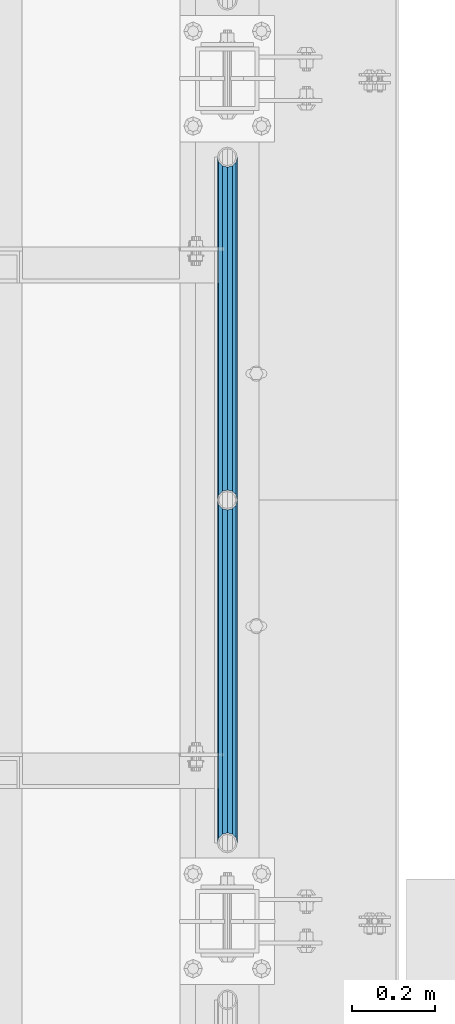
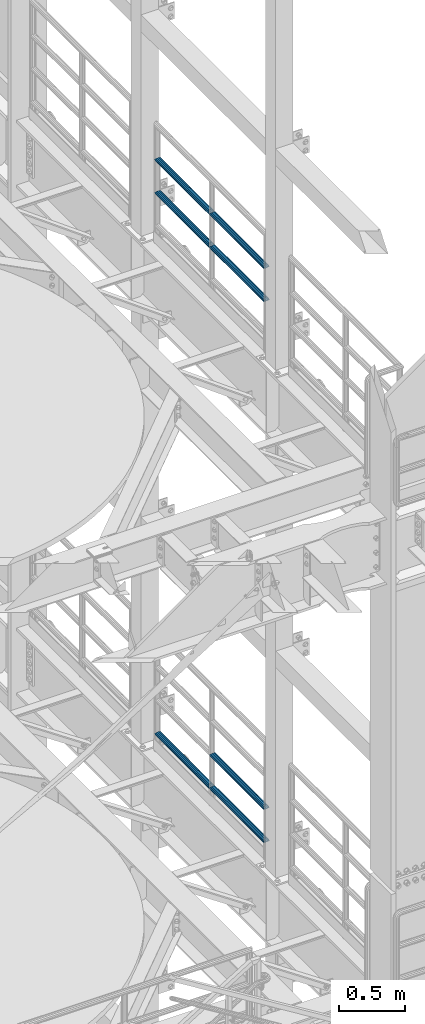
# One storey, part 1263 of 1876: 7 beams, 2 elements without a shape of their own.
"""IFC2X3 building model written with IfcOpenShell, lengths in millimetres."""

import ifcopenshell
import ifcopenshell.guid

model = None  # the IFC model being written
_history = None  # IfcOwnerHistory: only IFC2X3 demands one
_inside = {}  # id of a spatial element -> (the spatial element, [elements in it])
_under = {}  # id of a project, library or spatial element -> (it, [spatial elements below it])
_declared = {}  # id of a project -> (the project, [libraries it declares])
_typed = {}  # id of a type object -> (the type object, [elements of that type])
_made_of = {}  # id of a material, layer set ... -> (it, [elements and type objects made of it])


def new_model(schema):
    """Start an empty IFC model of exactly this schema.

    Asked for "IFC4X3", IfcOpenShell would pick the latest addendum, in which some entities
    have other attributes; the version numbers below select the first issue.
    IFC2X3 requires an IfcOwnerHistory on every rooted entity: one is made here for all.
    """
    global model, _history
    if schema == "IFC4X3":
        model = ifcopenshell.file(schema_version=(4, 3, 0, 0))
    else:
        model = ifcopenshell.file(schema=schema)
    _inside.clear()
    _under.clear()
    _declared.clear()
    _typed.clear()
    _made_of.clear()
    _history = None
    if model.schema == "IFC2X3":
        org = make("IfcOrganization", Name="unknown")
        user = make(
            "IfcPersonAndOrganization",
            ThePerson=make("IfcPerson", FamilyName="unknown"),
            TheOrganization=org,
        )
        app = make(
            "IfcApplication",
            ApplicationDeveloper=org,
            Version="unknown",
            ApplicationFullName="unknown",
            ApplicationIdentifier="unknown",
        )
        _history = make(
            "IfcOwnerHistory",
            OwningUser=user,
            OwningApplication=app,
            ChangeAction="ADDED",
            CreationDate=0,
        )
    return model


def make(cls, **values):
    """One entity of the class cls with the attributes given. An attribute that is None is left unset."""
    return model.create_entity(
        cls, **{name: value for name, value in values.items() if value is not None}
    )


def rooted(cls, **values):
    """An entity with a GlobalId (a new one), such as an element, a storey or a relation."""
    return make(cls, GlobalId=ifcopenshell.guid.new(), OwnerHistory=_history, **values)


def si_unit(unit_type, name, prefix=None):
    """IfcSIUnit, for example si_unit("LENGTHUNIT", "METRE", prefix="MILLI")."""
    return make("IfcSIUnit", UnitType=unit_type, Prefix=prefix, Name=name)


def assignment(units):
    """IfcUnitAssignment: the units of a project."""
    return None if units is None else make("IfcUnitAssignment", Units=units)


def point(xyz):
    """IfcCartesianPoint."""
    return None if xyz is None else make("IfcCartesianPoint", Coordinates=xyz)


def direction(xyz):
    """IfcDirection."""
    return None if xyz is None else make("IfcDirection", DirectionRatios=xyz)


def frame(location, z_axis=None, x_axis=None):
    """IfcAxis2Placement3D, a coordinate frame: its origin and axes. An axis left out is left unset."""
    return make(
        "IfcAxis2Placement3D",
        Location=point(location),
        Axis=direction(z_axis),
        RefDirection=direction(x_axis),
    )


def origin_with_axes():
    """The frame at (0, 0, 0) with the z axis (0, 0, 1) and the x axis (1, 0, 0) written out."""
    return frame((0.0, 0.0, 0.0), z_axis=(0.0, 0.0, 1.0), x_axis=(1.0, 0.0, 0.0))


def place(relative_to, where):
    """IfcLocalPlacement: puts the frame where relative to a parent placement (None: the world)."""
    return make(
        "IfcLocalPlacement", PlacementRelTo=relative_to, RelativePlacement=where
    )


def context(
    kind, dimensions, precision=None, world=None, true_north=None, identifier=None
):
    """IfcGeometricRepresentationContext, for example the 3D "Model" context."""
    return make(
        "IfcGeometricRepresentationContext",
        ContextIdentifier=identifier,
        ContextType=kind,
        CoordinateSpaceDimension=dimensions,
        Precision=precision,
        WorldCoordinateSystem=world,
        TrueNorth=true_north,
    )


def subcontext(parent, identifier, kind, view, scale=None):
    """IfcGeometricRepresentationSubContext, for example "Body" below "Model"."""
    return make(
        "IfcGeometricRepresentationSubContext",
        ContextIdentifier=identifier,
        ContextType=kind,
        ParentContext=parent,
        TargetScale=scale,
        TargetView=view,
    )


def project(units=None, contexts=None):
    """IfcProject with its units and contexts."""
    return rooted(
        "IfcProject",
        Name="project",
        RepresentationContexts=contexts,
        UnitsInContext=assignment(units),
    )


def spatial(cls, under=None, at=None, **own):
    """A site, building, storey or space (cls), placed at a placement, below another one or the project."""
    s = rooted(cls, ObjectPlacement=at, **own)
    if under is not None:
        _under.setdefault(under.id(), (under, []))[1].append(s)
    return s


def faces_of(points, faces, orient=None, outer=None):
    """IfcFace entities. A face is a list of loops; a loop is a list of indices into points, from 0.

    orient and outer hold one flag for each loop. By default every Orientation is true, the
    first loop of a face is its IfcFaceOuterBound and the others are IfcFaceBound.
    """
    made = []
    for i, loops in enumerate(faces):
        bounds = []
        for j, loop in enumerate(loops):
            is_outer = j == 0 if outer is None else outer[i][j]
            bounds.append(
                make(
                    "IfcFaceOuterBound" if is_outer else "IfcFaceBound",
                    Bound=make("IfcPolyLoop", Polygon=[points[k] for k in loop]),
                    Orientation=True if orient is None else orient[i][j],
                )
            )
        made.append(make("IfcFace", Bounds=bounds))
    return made


def faceted_brep(points, faces, orient=None, outer=None, voids=None):
    """IfcFacetedBrep: a solid bounded by flat faces; with voids (closed shells), ...WithVoids."""
    shared = [point(p) for p in points]
    hull = make("IfcClosedShell", CfsFaces=faces_of(shared, faces, orient, outer))
    if voids is None:
        return make("IfcFacetedBrep", Outer=hull)
    return make(
        "IfcFacetedBrepWithVoids",
        Outer=hull,
        Voids=[
            make(cls, CfsFaces=faces_of(shared, fs, o, b)) for cls, fs, o, b in voids
        ],
    )


def shape(context_of_items, identifier, shape_type, items):
    """IfcShapeRepresentation: the items that make up one representation, for example the "Body"."""
    return make(
        "IfcShapeRepresentation",
        ContextOfItems=context_of_items,
        RepresentationIdentifier=identifier,
        RepresentationType=shape_type,
        Items=items,
    )


def material(Name=None, Category=None):
    """IfcMaterial."""
    return make("IfcMaterial", Name=Name, Category=Category)


def made_of(thing, what):
    """Note that an element or type object is made of a material, layer set ...; save() writes the relation."""
    if what is not None:
        _made_of.setdefault(what.id(), (what, []))[1].append(thing)
    return thing


def type_object(cls, material=None, **own):
    """A type object (cls), such as IfcWallType, which elements share."""
    return made_of(rooted(cls, **own), material)


def element(
    cls,
    number,
    at=None,
    inside=None,
    cuts=None,
    type_object=None,
    material=None,
    context=None,
    identifier="Body",
    shape_type=None,
    held_by="IfcProductDefinitionShape",
    body=None,
    shapes=None,
    **own,
):
    """One element of the class cls, such as IfcWall. Its Tag is "e" and its number.

    at: its placement. inside: the storey or other place that contains it. cuts: it is an
    opening in that element (IfcRelVoidsElement). A single representation is given by context,
    identifier, shape_type and body (its items); several are given by shapes. held_by: the class
    of the entity that holds the representations. save() writes the other relations.
    """
    e = rooted(cls, Tag="e%d" % number, ObjectPlacement=at, **own)
    if body is not None:
        shapes = [shape(context, identifier, shape_type, body)]
    if shapes is not None:
        e.Representation = make(held_by, Representations=shapes)
    if inside is not None:
        _inside.setdefault(inside.id(), (inside, []))[1].append(e)
    if cuts is not None:
        rooted(
            "IfcRelVoidsElement", RelatingBuildingElement=cuts, RelatedOpeningElement=e
        )
    if type_object is not None:
        _typed.setdefault(type_object.id(), (type_object, []))[1].append(e)
    return made_of(e, material)


def aggregate(whole, parts):
    """IfcRelAggregates: a whole, such as a stair, and the parts it consists of."""
    return rooted("IfcRelAggregates", RelatingObject=whole, RelatedObjects=parts)


def save(model, path):
    """Write the relations noted so far, then the file.

    IfcRelAggregates (storeys below a building ...), IfcRelContainedInSpatialStructure (elements
    in a storey), IfcRelDefinesByType, IfcRelAssociatesMaterial and IfcRelDeclares: one each for
    every whole, place, type object, material and project.
    """
    for whole, parts in _under.values():
        aggregate(whole, parts)
    for where, things in _inside.values():
        rooted(
            "IfcRelContainedInSpatialStructure",
            RelatedElements=things,
            RelatingStructure=where,
        )
    for kind, things in _typed.values():
        rooted("IfcRelDefinesByType", RelatedObjects=things, RelatingType=kind)
    for what, things in _made_of.values():
        rooted("IfcRelAssociatesMaterial", RelatedObjects=things, RelatingMaterial=what)
    for by, libraries in _declared.values():
        rooted("IfcRelDeclares", RelatingContext=by, RelatedDefinitions=libraries)
    model.write(path)


model = new_model("IFC2X3")

# Units and contexts
model_context = context("Model", 3, precision=1e-05, world=origin_with_axes())
body_context = subcontext(model_context, "Body", "Model", "MODEL_VIEW")
ifc_project = project(units=[si_unit("LENGTHUNIT", "METRE", prefix="MILLI"), si_unit("AREAUNIT", "SQUARE_METRE"), si_unit("VOLUMEUNIT", "CUBIC_METRE"), si_unit("MASSUNIT", "GRAM", prefix="KILO"), si_unit("TIMEUNIT", "SECOND"), si_unit("PLANEANGLEUNIT", "RADIAN"), si_unit("SOLIDANGLEUNIT", "STERADIAN"), si_unit("THERMODYNAMICTEMPERATUREUNIT", "DEGREE_CELSIUS"), si_unit("LUMINOUSINTENSITYUNIT", "LUMEN")], contexts=[model_context])

# Site, building, storey
site_placement = place(None, origin_with_axes())
site = spatial("IfcSite", under=ifc_project, at=site_placement, CompositionType="ELEMENT")
building_placement = place(site_placement, origin_with_axes())
building = spatial("IfcBuilding", under=site, at=building_placement, Name="Undefined", CompositionType="ELEMENT")
storey_placement = place(building_placement, origin_with_axes())
storey = spatial("IfcBuildingStorey", under=building, at=storey_placement, Name="Undefined", CompositionType="ELEMENT", Elevation=0.0)

# Assembly, beams
assembly_1_placement = place(storey_placement, origin_with_axes())
assembly_1 = element("IfcElementAssembly", 1, at=assembly_1_placement, inside=storey, Name="RAIL", AssemblyPlace="NOTDEFINED", PredefinedType="RIGID_FRAME")
ifc_material = material()
beam_type = type_object("IfcBeamType", Name="PIPE1-1/2SCH40", PredefinedType="NOTDEFINED")
beam_1_placement = place(assembly_1_placement, frame((7620.0, -2350.77, 18449.925), z_axis=(0.0, 0.0, -1.0), x_axis=(0.0, 1.0, 0.0)))
beam_1 = element("IfcBeam", 2, at=beam_1_placement, type_object=beam_type, material=ifc_material, Name="RAIL", ObjectType="PIPE1-1/2SCH40", context=body_context, shape_type="Brep", body=[
    faceted_brep([(0.0, 24.1299999999992, 0.0), (12.0650000000064, 20.8971929933177, -12.0649999999987), (12.0650000000064, 20.8971929933177, 12.0649999999987), (12.0650000000064, -20.8971929933177, 12.0649999999987), (12.0650000000064, -20.8971929933177, -12.0649999999987), (0.0, -24.1299999999992, 0.0), (20.8971929933249, -12.0650000000005, 20.8971929933177), (20.8971929933249, -12.0650000000005, 15.8661214311796), (15.2545715621445, -17.7076214311801, 10.2235000000001), (12.5151929933249, -20.4470000000001, 0.0), (15.2545715621445, -17.7076214311801, -10.2235000000001), (20.8971929933249, -12.0650000000005, -15.8661214311796), (20.8971929933249, -12.0650000000005, -20.8971929933177), (24.1300000000063, 0.0, -20.4470000000001), (24.1300000000063, 0.0, -24.130000000001), (21.3906214311868, -10.2235000000001, -17.7076214311819), (21.3906214311868, 10.2235000000001, -17.7076214311819), (20.8971929933249, 12.0650000000005, -15.8661214311796), (20.8971929933249, 12.0650000000005, -20.8971929933177), (15.2545715621445, 17.7076214311801, -10.2235000000001), (12.5151929933249, 20.4470000000001, 0.0), (15.2545715621445, 17.7076214311801, 10.2235000000001), (20.8971929933249, 12.0650000000005, 15.8661214311796), (20.8971929933249, 12.0650000000005, 20.8971929933177), (21.3906214311868, 10.2235000000001, 17.7076214311819), (24.1300000000064, 0.0, 20.4470000000001), (24.1300000000064, 0.0, 24.130000000001), (21.3906214311868, -10.2235000000001, 17.7076214311819), (826.77, 24.1300000000001, 0.0), (814.705, 20.8971929933186, -12.0649999999987), (805.872807006681, 12.0649999999996, -20.8971929933177), (826.77, -24.1300000000001, 0.0), (814.705, -20.8971929933186, -12.0649999999987), (814.705, -20.8971929933186, 12.0649999999987), (805.872807006681, -12.0649999999996, 20.8971929933177), (805.872807006681, -12.0649999999996, -20.8971929933177), (802.640000000001, 0.0, -24.130000000001), (805.379378568819, 10.2235000000001, -17.7076214311819), (802.640000000001, 0.0, -20.4470000000001), (805.872807006683, 12.0649999999996, -15.8661214311796), (805.872807006683, -12.0649999999996, -15.8661214311796), (805.379378568819, -10.2235000000001, -17.7076214311819), (811.515428437862, -17.7076214311801, -10.2235000000001), (814.254807006682, -20.4470000000001, 0.0), (811.515428437862, -17.7076214311801, 10.2235000000001), (805.872807006683, -12.0649999999996, 15.8661214311796), (805.379378568819, -10.2235000000001, 17.7076214311819), (802.640000000001, 0.0, 20.4470000000001), (802.640000000001, 0.0, 24.130000000001), (805.872807006681, 12.0649999999996, 20.8971929933177), (814.705, 20.8971929933186, 12.0649999999987), (805.872807006683, 12.0649999999996, 15.8661214311796), (811.515428437862, 17.7076214311801, 10.2235000000001), (814.254807006682, 20.4470000000001, 0.0), (811.515428437862, 17.7076214311801, -10.2235000000001), (805.379378568819, 10.2235000000001, 17.7076214311819)], [[[0, 1, 2]], [[3, 4, 5]], [[6, 7, 8, 9, 10, 11, 12, 4, 3]], [[13, 14, 12, 11, 15]], [[16, 17, 18, 14, 13]], [[2, 1, 18, 17, 19, 20, 21, 22, 23]], [[23, 22, 24, 25, 26]], [[26, 25, 27, 7, 6]], [[1, 0, 28, 29]], [[18, 1, 29, 30]], [[31, 32, 33]], [[6, 3, 33, 34]], [[3, 5, 31, 33]], [[5, 4, 32, 31]], [[4, 12, 35, 32]], [[12, 14, 36, 35]], [[14, 18, 30, 36]], [[37, 38, 36, 30, 39]], [[40, 35, 36, 38, 41]], [[33, 32, 35, 40, 42, 43, 44, 45, 34]], [[34, 45, 46, 47, 48]], [[26, 6, 34, 48]], [[2, 23, 49, 50]], [[23, 26, 48, 49]], [[0, 2, 50, 28]], [[28, 50, 29]], [[49, 51, 52, 53, 54, 39, 30, 29, 50]], [[48, 47, 55, 51, 49]], [[25, 24, 55, 47]], [[55, 24, 22, 21, 52, 51]], [[21, 20, 53, 52]], [[20, 19, 54, 53]], [[19, 17, 16, 37, 39, 54]], [[16, 13, 38, 37]], [[13, 15, 41, 38]], [[41, 15, 11, 10, 42, 40]], [[10, 9, 43, 42]], [[9, 8, 44, 43]], [[8, 7, 27, 46, 45, 44]], [[27, 25, 47, 46]]]),
])
beam_2_placement = place(assembly_1_placement, frame((7620.0, -1524.0, 18449.925), z_axis=(0.0, 0.0, -1.0), x_axis=(0.0, 1.0, 0.0)))
beam_2 = element("IfcBeam", 3, at=beam_2_placement, type_object=beam_type, material=ifc_material, Name="RAIL", ObjectType="PIPE1-1/2SCH40", context=body_context, shape_type="Brep", body=[
    faceted_brep([(0.0, 24.1299999999992, 0.0), (12.0650000000064, 20.8971929933177, -12.0649999999987), (12.0650000000064, 20.8971929933177, 12.0649999999987), (12.0650000000064, -20.8971929933177, 12.0649999999987), (12.0650000000064, -20.8971929933177, -12.0649999999987), (0.0, -24.1299999999992, 0.0), (20.8971929933249, -12.0650000000005, 20.8971929933177), (20.8971929933249, -12.0650000000005, 15.8661214311796), (15.2545715621445, -17.7076214311801, 10.2235000000001), (12.5151929933249, -20.4470000000001, 0.0), (15.2545715621445, -17.7076214311801, -10.2235000000001), (20.8971929933249, -12.0650000000005, -15.8661214311796), (20.8971929933249, -12.0650000000005, -20.8971929933177), (24.1300000000063, 0.0, -20.4470000000001), (24.1300000000063, 0.0, -24.130000000001), (21.3906214311868, -10.2235000000001, -17.7076214311819), (21.3906214311868, 10.2235000000001, -17.7076214311819), (20.8971929933249, 12.0650000000005, -15.8661214311796), (20.8971929933249, 12.0650000000005, -20.8971929933177), (15.2545715621445, 17.7076214311801, -10.2235000000001), (12.5151929933249, 20.4470000000001, 0.0), (15.2545715621445, 17.7076214311801, 10.2235000000001), (20.8971929933249, 12.0650000000005, 15.8661214311796), (20.8971929933249, 12.0650000000005, 20.8971929933177), (21.3906214311868, 10.2235000000001, 17.7076214311819), (24.1300000000064, 0.0, 20.4470000000001), (24.1300000000064, 0.0, 24.130000000001), (21.3906214311868, -10.2235000000001, 17.7076214311819), (826.77, 24.1300000000001, 0.0), (814.705, 20.8971929933186, -12.0649999999987), (805.872807006681, 12.0649999999996, -20.8971929933177), (826.77, -24.1300000000001, 0.0), (814.705, -20.8971929933186, -12.0649999999987), (814.705, -20.8971929933186, 12.0649999999987), (805.872807006681, -12.0649999999996, 20.8971929933177), (805.872807006681, -12.0649999999996, -20.8971929933177), (802.640000000001, 0.0, -24.130000000001), (805.379378568819, 10.2235000000001, -17.7076214311819), (802.640000000001, 0.0, -20.4470000000001), (805.872807006683, 12.0649999999996, -15.8661214311796), (805.872807006683, -12.0649999999996, -15.8661214311796), (805.379378568819, -10.2235000000001, -17.7076214311819), (811.515428437862, -17.7076214311801, -10.2235000000001), (814.254807006682, -20.4470000000001, 0.0), (811.515428437862, -17.7076214311801, 10.2235000000001), (805.872807006683, -12.0649999999996, 15.8661214311796), (805.379378568819, -10.2235000000001, 17.7076214311819), (802.640000000001, 0.0, 20.4470000000001), (802.640000000001, 0.0, 24.130000000001), (805.872807006681, 12.0649999999996, 20.8971929933177), (814.705, 20.8971929933186, 12.0649999999987), (805.872807006683, 12.0649999999996, 15.8661214311796), (811.515428437862, 17.7076214311801, 10.2235000000001), (814.254807006682, 20.4470000000001, 0.0), (811.515428437862, 17.7076214311801, -10.2235000000001), (805.379378568819, 10.2235000000001, 17.7076214311819)], [[[0, 1, 2]], [[3, 4, 5]], [[6, 7, 8, 9, 10, 11, 12, 4, 3]], [[13, 14, 12, 11, 15]], [[16, 17, 18, 14, 13]], [[2, 1, 18, 17, 19, 20, 21, 22, 23]], [[23, 22, 24, 25, 26]], [[26, 25, 27, 7, 6]], [[1, 0, 28, 29]], [[18, 1, 29, 30]], [[31, 32, 33]], [[6, 3, 33, 34]], [[3, 5, 31, 33]], [[5, 4, 32, 31]], [[4, 12, 35, 32]], [[12, 14, 36, 35]], [[14, 18, 30, 36]], [[37, 38, 36, 30, 39]], [[40, 35, 36, 38, 41]], [[33, 32, 35, 40, 42, 43, 44, 45, 34]], [[34, 45, 46, 47, 48]], [[26, 6, 34, 48]], [[2, 23, 49, 50]], [[23, 26, 48, 49]], [[0, 2, 50, 28]], [[28, 50, 29]], [[49, 51, 52, 53, 54, 39, 30, 29, 50]], [[48, 47, 55, 51, 49]], [[25, 24, 55, 47]], [[55, 24, 22, 21, 52, 51]], [[21, 20, 53, 52]], [[20, 19, 54, 53]], [[19, 17, 16, 37, 39, 54]], [[16, 13, 38, 37]], [[13, 15, 41, 38]], [[41, 15, 11, 10, 42, 40]], [[10, 9, 43, 42]], [[9, 8, 44, 43]], [[8, 7, 27, 46, 45, 44]], [[27, 25, 47, 46]]]),
])
beam_3_placement = place(assembly_1_placement, frame((7620.0, -2350.77, 18754.725), z_axis=(0.0, 0.0, -1.0), x_axis=(0.0, 1.0, 0.0)))
beam_3 = element("IfcBeam", 4, at=beam_3_placement, type_object=beam_type, material=ifc_material, Name="RAIL", ObjectType="PIPE1-1/2SCH40", context=body_context, shape_type="Brep", body=[
    faceted_brep([(0.0, 24.1299999999992, 0.0), (12.0650000000064, 20.8971929933177, -12.0649999999987), (12.0650000000064, 20.8971929933177, 12.0649999999987), (12.0650000000064, -20.8971929933177, 12.0649999999987), (12.0650000000064, -20.8971929933177, -12.0649999999987), (0.0, -24.1299999999992, 0.0), (20.8971929933249, -12.0650000000005, 20.8971929933177), (20.8971929933249, -12.0650000000005, 15.8661214311796), (15.2545715621445, -17.7076214311801, 10.2235000000001), (12.5151929933249, -20.4470000000001, 0.0), (15.2545715621445, -17.7076214311801, -10.2235000000001), (20.8971929933249, -12.0650000000005, -15.8661214311796), (20.8971929933249, -12.0650000000005, -20.8971929933177), (24.1300000000063, 0.0, -20.4470000000001), (24.1300000000063, 0.0, -24.130000000001), (21.3906214311868, -10.2235000000001, -17.7076214311819), (21.3906214311868, 10.2235000000001, -17.7076214311819), (20.8971929933249, 12.0650000000005, -15.8661214311796), (20.8971929933249, 12.0650000000005, -20.8971929933177), (15.2545715621445, 17.7076214311801, -10.2235000000001), (12.5151929933249, 20.4470000000001, 0.0), (15.2545715621445, 17.7076214311801, 10.2235000000001), (20.8971929933249, 12.0650000000005, 15.8661214311796), (20.8971929933249, 12.0650000000005, 20.8971929933177), (21.3906214311868, 10.2235000000001, 17.7076214311819), (24.1300000000064, 0.0, 20.4470000000001), (24.1300000000064, 0.0, 24.130000000001), (21.3906214311868, -10.2235000000001, 17.7076214311819), (826.77, 24.1300000000001, 0.0), (814.705, 20.8971929933186, -12.0649999999987), (805.872807006681, 12.0649999999996, -20.8971929933177), (826.77, -24.1300000000001, 0.0), (814.705, -20.8971929933186, -12.0649999999987), (814.705, -20.8971929933186, 12.0649999999987), (805.872807006681, -12.0649999999996, 20.8971929933177), (805.872807006681, -12.0649999999996, -20.8971929933177), (802.640000000001, 0.0, -24.130000000001), (805.379378568819, 10.2235000000001, -17.7076214311819), (802.640000000001, 0.0, -20.4470000000001), (805.872807006683, 12.0649999999996, -15.8661214311796), (805.872807006683, -12.0649999999996, -15.8661214311796), (805.379378568819, -10.2235000000001, -17.7076214311819), (811.515428437862, -17.7076214311801, -10.2235000000001), (814.254807006682, -20.4470000000001, 0.0), (811.515428437862, -17.7076214311801, 10.2235000000001), (805.872807006683, -12.0649999999996, 15.8661214311796), (805.379378568819, -10.2235000000001, 17.7076214311819), (802.640000000001, 0.0, 20.4470000000001), (802.640000000001, 0.0, 24.130000000001), (805.872807006681, 12.0649999999996, 20.8971929933177), (814.705, 20.8971929933186, 12.0649999999987), (805.872807006683, 12.0649999999996, 15.8661214311796), (811.515428437862, 17.7076214311801, 10.2235000000001), (814.254807006682, 20.4470000000001, 0.0), (811.515428437862, 17.7076214311801, -10.2235000000001), (805.379378568819, 10.2235000000001, 17.7076214311819)], [[[0, 1, 2]], [[3, 4, 5]], [[6, 7, 8, 9, 10, 11, 12, 4, 3]], [[13, 14, 12, 11, 15]], [[16, 17, 18, 14, 13]], [[2, 1, 18, 17, 19, 20, 21, 22, 23]], [[23, 22, 24, 25, 26]], [[26, 25, 27, 7, 6]], [[1, 0, 28, 29]], [[18, 1, 29, 30]], [[31, 32, 33]], [[6, 3, 33, 34]], [[3, 5, 31, 33]], [[5, 4, 32, 31]], [[4, 12, 35, 32]], [[12, 14, 36, 35]], [[14, 18, 30, 36]], [[37, 38, 36, 30, 39]], [[40, 35, 36, 38, 41]], [[33, 32, 35, 40, 42, 43, 44, 45, 34]], [[34, 45, 46, 47, 48]], [[26, 6, 34, 48]], [[2, 23, 49, 50]], [[23, 26, 48, 49]], [[0, 2, 50, 28]], [[28, 50, 29]], [[49, 51, 52, 53, 54, 39, 30, 29, 50]], [[48, 47, 55, 51, 49]], [[25, 24, 55, 47]], [[55, 24, 22, 21, 52, 51]], [[21, 20, 53, 52]], [[20, 19, 54, 53]], [[19, 17, 16, 37, 39, 54]], [[16, 13, 38, 37]], [[13, 15, 41, 38]], [[41, 15, 11, 10, 42, 40]], [[10, 9, 43, 42]], [[9, 8, 44, 43]], [[8, 7, 27, 46, 45, 44]], [[27, 25, 47, 46]]]),
])
beam_4_placement = place(assembly_1_placement, frame((7620.0, -1524.0, 18754.725), z_axis=(0.0, 0.0, -1.0), x_axis=(0.0, 1.0, 0.0)))
beam_4 = element("IfcBeam", 5, at=beam_4_placement, type_object=beam_type, material=ifc_material, Name="RAIL", ObjectType="PIPE1-1/2SCH40", context=body_context, shape_type="Brep", body=[
    faceted_brep([(0.0, 24.1299999999992, 0.0), (12.0650000000064, 20.8971929933177, -12.0649999999987), (12.0650000000064, 20.8971929933177, 12.0649999999987), (12.0650000000064, -20.8971929933177, 12.0649999999987), (12.0650000000064, -20.8971929933177, -12.0649999999987), (0.0, -24.1299999999992, 0.0), (20.8971929933249, -12.0650000000005, 20.8971929933177), (20.8971929933249, -12.0650000000005, 15.8661214311796), (15.2545715621445, -17.7076214311801, 10.2235000000001), (12.5151929933249, -20.4470000000001, 0.0), (15.2545715621445, -17.7076214311801, -10.2235000000001), (20.8971929933249, -12.0650000000005, -15.8661214311796), (20.8971929933249, -12.0650000000005, -20.8971929933177), (24.1300000000063, 0.0, -20.4470000000001), (24.1300000000063, 0.0, -24.130000000001), (21.3906214311868, -10.2235000000001, -17.7076214311819), (21.3906214311868, 10.2235000000001, -17.7076214311819), (20.8971929933249, 12.0650000000005, -15.8661214311796), (20.8971929933249, 12.0650000000005, -20.8971929933177), (15.2545715621445, 17.7076214311801, -10.2235000000001), (12.5151929933249, 20.4470000000001, 0.0), (15.2545715621445, 17.7076214311801, 10.2235000000001), (20.8971929933249, 12.0650000000005, 15.8661214311796), (20.8971929933249, 12.0650000000005, 20.8971929933177), (21.3906214311868, 10.2235000000001, 17.7076214311819), (24.1300000000064, 0.0, 20.4470000000001), (24.1300000000064, 0.0, 24.130000000001), (21.3906214311868, -10.2235000000001, 17.7076214311819), (826.77, 24.1300000000001, 0.0), (814.705, 20.8971929933186, -12.0649999999987), (805.872807006681, 12.0649999999996, -20.8971929933177), (826.77, -24.1300000000001, 0.0), (814.705, -20.8971929933186, -12.0649999999987), (814.705, -20.8971929933186, 12.0649999999987), (805.872807006681, -12.0649999999996, 20.8971929933177), (805.872807006681, -12.0649999999996, -20.8971929933177), (802.640000000001, 0.0, -24.130000000001), (805.379378568819, 10.2235000000001, -17.7076214311819), (802.640000000001, 0.0, -20.4470000000001), (805.872807006683, 12.0649999999996, -15.8661214311796), (805.872807006683, -12.0649999999996, -15.8661214311796), (805.379378568819, -10.2235000000001, -17.7076214311819), (811.515428437862, -17.7076214311801, -10.2235000000001), (814.254807006682, -20.4470000000001, 0.0), (811.515428437862, -17.7076214311801, 10.2235000000001), (805.872807006683, -12.0649999999996, 15.8661214311796), (805.379378568819, -10.2235000000001, 17.7076214311819), (802.640000000001, 0.0, 20.4470000000001), (802.640000000001, 0.0, 24.130000000001), (805.872807006681, 12.0649999999996, 20.8971929933177), (814.705, 20.8971929933186, 12.0649999999987), (805.872807006683, 12.0649999999996, 15.8661214311796), (811.515428437862, 17.7076214311801, 10.2235000000001), (814.254807006682, 20.4470000000001, 0.0), (811.515428437862, 17.7076214311801, -10.2235000000001), (805.379378568819, 10.2235000000001, 17.7076214311819)], [[[0, 1, 2]], [[3, 4, 5]], [[6, 7, 8, 9, 10, 11, 12, 4, 3]], [[13, 14, 12, 11, 15]], [[16, 17, 18, 14, 13]], [[2, 1, 18, 17, 19, 20, 21, 22, 23]], [[23, 22, 24, 25, 26]], [[26, 25, 27, 7, 6]], [[1, 0, 28, 29]], [[18, 1, 29, 30]], [[31, 32, 33]], [[6, 3, 33, 34]], [[3, 5, 31, 33]], [[5, 4, 32, 31]], [[4, 12, 35, 32]], [[12, 14, 36, 35]], [[14, 18, 30, 36]], [[37, 38, 36, 30, 39]], [[40, 35, 36, 38, 41]], [[33, 32, 35, 40, 42, 43, 44, 45, 34]], [[34, 45, 46, 47, 48]], [[26, 6, 34, 48]], [[2, 23, 49, 50]], [[23, 26, 48, 49]], [[0, 2, 50, 28]], [[28, 50, 29]], [[49, 51, 52, 53, 54, 39, 30, 29, 50]], [[48, 47, 55, 51, 49]], [[25, 24, 55, 47]], [[55, 24, 22, 21, 52, 51]], [[21, 20, 53, 52]], [[20, 19, 54, 53]], [[19, 17, 16, 37, 39, 54]], [[16, 13, 38, 37]], [[13, 15, 41, 38]], [[41, 15, 11, 10, 42, 40]], [[10, 9, 43, 42]], [[9, 8, 44, 43]], [[8, 7, 27, 46, 45, 44]], [[27, 25, 47, 46]]]),
])
aggregate(assembly_1, [beam_1, beam_2, beam_3, beam_4])

assembly_2_placement = place(storey_placement, origin_with_axes())
assembly_2 = element("IfcElementAssembly", 6, at=assembly_2_placement, inside=storey, Name="RAIL", AssemblyPlace="NOTDEFINED", PredefinedType="RIGID_FRAME")
beam_5_placement = place(assembly_2_placement, frame((7620.0, -1524.0, 13471.525), z_axis=(0.0, 0.0, 1.0), x_axis=(0.0, -1.0, 0.0)))
beam_5 = element("IfcBeam", 7, at=beam_5_placement, type_object=beam_type, material=ifc_material, Name="RAIL", ObjectType="PIPE1-1/2SCH40", context=body_context, shape_type="Brep", body=[
    faceted_brep([(805.872807006681, -12.0649999999996, 20.8971929933177), (805.872807006683, -12.0649999999996, 15.8661214311796), (805.379378568819, -10.2235000000001, 17.7076214311819), (802.640000000001, 0.0, 20.4470000000001), (802.640000000001, 0.0, 24.130000000001), (805.379378568819, 10.2235000000001, 17.7076214311819), (805.872807006683, 12.0649999999996, 15.8661214311796), (805.872807006681, 12.0649999999996, 20.8971929933177), (826.77, 24.1300000000001, 0.0), (814.705, 20.8971929933186, 12.0649999999987), (814.705, 20.8971929933186, -12.0649999999987), (811.515428437862, 17.7076214311801, 10.2235000000001), (814.254807006682, 20.4470000000001, 0.0), (811.515428437862, 17.7076214311801, -10.2235000000001), (805.872807006683, 12.0649999999996, -15.8661214311796), (805.872807006681, 12.0649999999996, -20.8971929933177), (805.379378568819, 10.2235000000001, -17.7076214311819), (802.640000000001, 0.0, -20.4470000000001), (802.640000000001, 0.0, -24.130000000001), (805.872807006683, -12.0649999999996, -15.8661214311796), (805.872807006681, -12.0649999999996, -20.8971929933177), (805.379378568819, -10.2235000000001, -17.7076214311819), (826.77, -24.1300000000001, 0.0), (814.705, -20.8971929933186, -12.0649999999987), (814.705, -20.8971929933186, 12.0649999999987), (811.515428437862, -17.7076214311801, -10.2235000000001), (814.254807006682, -20.4470000000001, 0.0), (811.515428437862, -17.7076214311801, 10.2235000000001), (12.0650000000064, -20.8971929933177, -12.0649999999987), (20.8971929933249, -12.0650000000005, -20.8971929933177), (0.0, 24.1299999999992, 0.0), (12.0650000000064, 20.8971929933177, -12.0649999999987), (12.0650000000064, 20.8971929933177, 12.0649999999987), (20.8971929933249, 12.0650000000005, 20.8971929933177), (24.1300000000064, 0.0, 24.130000000001), (20.8971929933249, 12.0650000000005, -20.8971929933177), (24.1300000000063, 0.0, -24.130000000001), (24.1300000000063, 0.0, -20.4470000000001), (20.8971929933249, -12.0650000000005, -15.8661214311796), (21.3906214311868, -10.2235000000001, -17.7076214311819), (21.3906214311868, 10.2235000000001, -17.7076214311819), (20.8971929933249, 12.0650000000005, -15.8661214311796), (15.2545715621445, 17.7076214311801, -10.2235000000001), (12.5151929933249, 20.4470000000001, 0.0), (15.2545715621445, 17.7076214311801, 10.2235000000001), (20.8971929933249, 12.0650000000005, 15.8661214311796), (21.3906214311868, 10.2235000000001, 17.7076214311819), (24.1300000000064, 0.0, 20.4470000000001), (21.3906214311868, -10.2235000000001, 17.7076214311819), (20.8971929933249, -12.0650000000005, 15.8661214311796), (20.8971929933249, -12.0650000000005, 20.8971929933177), (12.0650000000064, -20.8971929933177, 12.0649999999987), (0.0, -24.1299999999992, 0.0), (15.2545715621445, -17.7076214311801, 10.2235000000001), (12.5151929933249, -20.4470000000001, 0.0), (15.2545715621445, -17.7076214311801, -10.2235000000001)], [[[0, 1, 2, 3, 4]], [[4, 3, 5, 6, 7]], [[8, 9, 10]], [[7, 6, 11, 12, 13, 14, 15, 10, 9]], [[16, 17, 18, 15, 14]], [[19, 20, 18, 17, 21]], [[22, 23, 24]], [[24, 23, 20, 19, 25, 26, 27, 1, 0]], [[28, 29, 20, 23]], [[30, 31, 32]], [[33, 34, 4, 7]], [[32, 33, 7, 9]], [[30, 32, 9, 8]], [[31, 30, 8, 10]], [[35, 31, 10, 15]], [[36, 35, 15, 18]], [[29, 36, 18, 20]], [[37, 36, 29, 38, 39]], [[40, 41, 35, 36, 37]], [[32, 31, 35, 41, 42, 43, 44, 45, 33]], [[33, 45, 46, 47, 34]], [[34, 47, 48, 49, 50]], [[34, 50, 0, 4]], [[50, 51, 24, 0]], [[51, 52, 22, 24]], [[52, 28, 23, 22]], [[51, 28, 52]], [[50, 49, 53, 54, 55, 38, 29, 28, 51]], [[55, 54, 26, 25]], [[21, 39, 38, 55, 25, 19]], [[37, 39, 21, 17]], [[40, 37, 17, 16]], [[42, 41, 40, 16, 14, 13]], [[43, 42, 13, 12]], [[44, 43, 12, 11]], [[5, 46, 45, 44, 11, 6]], [[47, 46, 5, 3]], [[48, 47, 3, 2]], [[53, 49, 48, 2, 1, 27]], [[54, 53, 27, 26]]]),
])
beam_6_placement = place(assembly_2_placement, frame((7620.0, -697.230000000005, 13471.525), z_axis=(0.0, 0.0, 1.0), x_axis=(0.0, -1.0, 0.0)))
beam_6 = element("IfcBeam", 8, at=beam_6_placement, type_object=beam_type, material=ifc_material, Name="RAIL", ObjectType="PIPE1-1/2SCH40", context=body_context, shape_type="Brep", body=[
    faceted_brep([(805.872807006681, -12.0649999999996, 20.8971929933177), (805.872807006683, -12.0649999999996, 15.8661214311796), (805.379378568819, -10.2235000000001, 17.7076214311819), (802.640000000001, 0.0, 20.4470000000001), (802.640000000001, 0.0, 24.130000000001), (805.379378568819, 10.2235000000001, 17.7076214311819), (805.872807006683, 12.0649999999996, 15.8661214311796), (805.872807006681, 12.0649999999996, 20.8971929933177), (826.77, 24.1300000000001, 0.0), (814.705, 20.8971929933186, 12.0649999999987), (814.705, 20.8971929933186, -12.0649999999987), (811.515428437862, 17.7076214311801, 10.2235000000001), (814.254807006682, 20.4470000000001, 0.0), (811.515428437862, 17.7076214311801, -10.2235000000001), (805.872807006683, 12.0649999999996, -15.8661214311796), (805.872807006681, 12.0649999999996, -20.8971929933177), (805.379378568819, 10.2235000000001, -17.7076214311819), (802.640000000001, 0.0, -20.4470000000001), (802.640000000001, 0.0, -24.130000000001), (805.872807006683, -12.0649999999996, -15.8661214311796), (805.872807006681, -12.0649999999996, -20.8971929933177), (805.379378568819, -10.2235000000001, -17.7076214311819), (826.77, -24.1300000000001, 0.0), (814.705, -20.8971929933186, -12.0649999999987), (814.705, -20.8971929933186, 12.0649999999987), (811.515428437862, -17.7076214311801, -10.2235000000001), (814.254807006682, -20.4470000000001, 0.0), (811.515428437862, -17.7076214311801, 10.2235000000001), (12.0650000000064, -20.8971929933177, -12.0649999999987), (20.8971929933249, -12.0650000000005, -20.8971929933177), (0.0, 24.1299999999992, 0.0), (12.0650000000064, 20.8971929933177, -12.0649999999987), (12.0650000000064, 20.8971929933177, 12.0649999999987), (20.8971929933249, 12.0650000000005, 20.8971929933177), (24.1300000000064, 0.0, 24.130000000001), (20.8971929933249, 12.0650000000005, -20.8971929933177), (24.1300000000063, 0.0, -24.130000000001), (24.1300000000063, 0.0, -20.4470000000001), (20.8971929933249, -12.0650000000005, -15.8661214311796), (21.3906214311868, -10.2235000000001, -17.7076214311819), (21.3906214311868, 10.2235000000001, -17.7076214311819), (20.8971929933249, 12.0650000000005, -15.8661214311796), (15.2545715621445, 17.7076214311801, -10.2235000000001), (12.5151929933249, 20.4470000000001, 0.0), (15.2545715621445, 17.7076214311801, 10.2235000000001), (20.8971929933249, 12.0650000000005, 15.8661214311796), (21.3906214311868, 10.2235000000001, 17.7076214311819), (24.1300000000064, 0.0, 20.4470000000001), (21.3906214311868, -10.2235000000001, 17.7076214311819), (20.8971929933249, -12.0650000000005, 15.8661214311796), (20.8971929933249, -12.0650000000005, 20.8971929933177), (12.0650000000064, -20.8971929933177, 12.0649999999987), (0.0, -24.1299999999992, 0.0), (15.2545715621445, -17.7076214311801, 10.2235000000001), (12.5151929933249, -20.4470000000001, 0.0), (15.2545715621445, -17.7076214311801, -10.2235000000001)], [[[0, 1, 2, 3, 4]], [[4, 3, 5, 6, 7]], [[8, 9, 10]], [[7, 6, 11, 12, 13, 14, 15, 10, 9]], [[16, 17, 18, 15, 14]], [[19, 20, 18, 17, 21]], [[22, 23, 24]], [[24, 23, 20, 19, 25, 26, 27, 1, 0]], [[28, 29, 20, 23]], [[30, 31, 32]], [[33, 34, 4, 7]], [[32, 33, 7, 9]], [[30, 32, 9, 8]], [[31, 30, 8, 10]], [[35, 31, 10, 15]], [[36, 35, 15, 18]], [[29, 36, 18, 20]], [[37, 36, 29, 38, 39]], [[40, 41, 35, 36, 37]], [[32, 31, 35, 41, 42, 43, 44, 45, 33]], [[33, 45, 46, 47, 34]], [[34, 47, 48, 49, 50]], [[34, 50, 0, 4]], [[50, 51, 24, 0]], [[51, 52, 22, 24]], [[52, 28, 23, 22]], [[51, 28, 52]], [[50, 49, 53, 54, 55, 38, 29, 28, 51]], [[55, 54, 26, 25]], [[21, 39, 38, 55, 25, 19]], [[37, 39, 21, 17]], [[40, 37, 17, 16]], [[42, 41, 40, 16, 14, 13]], [[43, 42, 13, 12]], [[44, 43, 12, 11]], [[5, 46, 45, 44, 11, 6]], [[47, 46, 5, 3]], [[48, 47, 3, 2]], [[53, 49, 48, 2, 1, 27]], [[54, 53, 27, 26]]]),
])
beam_7_placement = place(assembly_2_placement, frame((7620.0, -2350.77, 13776.325), z_axis=(0.0, 0.0, -1.0), x_axis=(0.0, 1.0, 0.0)))
beam_7 = element("IfcBeam", 9, at=beam_7_placement, type_object=beam_type, material=ifc_material, Name="RAIL", ObjectType="PIPE1-1/2SCH40", context=body_context, shape_type="Brep", body=[
    faceted_brep([(0.0, 24.1299999999992, 0.0), (12.0650000000064, 20.8971929933177, -12.0649999999987), (12.0650000000064, 20.8971929933177, 12.0649999999987), (12.0650000000064, -20.8971929933177, 12.0649999999987), (12.0650000000064, -20.8971929933177, -12.0649999999987), (0.0, -24.1299999999992, 0.0), (20.8971929933249, -12.0650000000005, 20.8971929933177), (20.8971929933249, -12.0650000000005, 15.8661214311796), (15.2545715621445, -17.7076214311801, 10.2235000000001), (12.5151929933249, -20.4470000000001, 0.0), (15.2545715621445, -17.7076214311801, -10.2235000000001), (20.8971929933249, -12.0650000000005, -15.8661214311796), (20.8971929933249, -12.0650000000005, -20.8971929933177), (24.1300000000063, 0.0, -20.4470000000001), (24.1300000000063, 0.0, -24.130000000001), (21.3906214311868, -10.2235000000001, -17.7076214311819), (21.3906214311868, 10.2235000000001, -17.7076214311819), (20.8971929933249, 12.0650000000005, -15.8661214311796), (20.8971929933249, 12.0650000000005, -20.8971929933177), (15.2545715621445, 17.7076214311801, -10.2235000000001), (12.5151929933249, 20.4470000000001, 0.0), (15.2545715621445, 17.7076214311801, 10.2235000000001), (20.8971929933249, 12.0650000000005, 15.8661214311796), (20.8971929933249, 12.0650000000005, 20.8971929933177), (21.3906214311868, 10.2235000000001, 17.7076214311819), (24.1300000000064, 0.0, 20.4470000000001), (24.1300000000064, 0.0, 24.130000000001), (21.3906214311868, -10.2235000000001, 17.7076214311819), (826.77, 24.1300000000001, 0.0), (814.705, 20.8971929933186, -12.0649999999987), (805.872807006681, 12.0649999999996, -20.8971929933177), (826.77, -24.1300000000001, 0.0), (814.705, -20.8971929933186, -12.0649999999987), (814.705, -20.8971929933186, 12.0649999999987), (805.872807006681, -12.0649999999996, 20.8971929933177), (805.872807006681, -12.0649999999996, -20.8971929933177), (802.640000000001, 0.0, -24.130000000001), (805.379378568819, 10.2235000000001, -17.7076214311819), (802.640000000001, 0.0, -20.4470000000001), (805.872807006683, 12.0649999999996, -15.8661214311796), (805.872807006683, -12.0649999999996, -15.8661214311796), (805.379378568819, -10.2235000000001, -17.7076214311819), (811.515428437862, -17.7076214311801, -10.2235000000001), (814.254807006682, -20.4470000000001, 0.0), (811.515428437862, -17.7076214311801, 10.2235000000001), (805.872807006683, -12.0649999999996, 15.8661214311796), (805.379378568819, -10.2235000000001, 17.7076214311819), (802.640000000001, 0.0, 20.4470000000001), (802.640000000001, 0.0, 24.130000000001), (805.872807006681, 12.0649999999996, 20.8971929933177), (814.705, 20.8971929933186, 12.0649999999987), (805.872807006683, 12.0649999999996, 15.8661214311796), (811.515428437862, 17.7076214311801, 10.2235000000001), (814.254807006682, 20.4470000000001, 0.0), (811.515428437862, 17.7076214311801, -10.2235000000001), (805.379378568819, 10.2235000000001, 17.7076214311819)], [[[0, 1, 2]], [[3, 4, 5]], [[6, 7, 8, 9, 10, 11, 12, 4, 3]], [[13, 14, 12, 11, 15]], [[16, 17, 18, 14, 13]], [[2, 1, 18, 17, 19, 20, 21, 22, 23]], [[23, 22, 24, 25, 26]], [[26, 25, 27, 7, 6]], [[1, 0, 28, 29]], [[18, 1, 29, 30]], [[31, 32, 33]], [[6, 3, 33, 34]], [[3, 5, 31, 33]], [[5, 4, 32, 31]], [[4, 12, 35, 32]], [[12, 14, 36, 35]], [[14, 18, 30, 36]], [[37, 38, 36, 30, 39]], [[40, 35, 36, 38, 41]], [[33, 32, 35, 40, 42, 43, 44, 45, 34]], [[34, 45, 46, 47, 48]], [[26, 6, 34, 48]], [[2, 23, 49, 50]], [[23, 26, 48, 49]], [[0, 2, 50, 28]], [[28, 50, 29]], [[49, 51, 52, 53, 54, 39, 30, 29, 50]], [[48, 47, 55, 51, 49]], [[25, 24, 55, 47]], [[55, 24, 22, 21, 52, 51]], [[21, 20, 53, 52]], [[20, 19, 54, 53]], [[19, 17, 16, 37, 39, 54]], [[16, 13, 38, 37]], [[13, 15, 41, 38]], [[41, 15, 11, 10, 42, 40]], [[10, 9, 43, 42]], [[9, 8, 44, 43]], [[8, 7, 27, 46, 45, 44]], [[27, 25, 47, 46]]]),
])
aggregate(assembly_2, [beam_5, beam_6, beam_7])

save(model, "model.ifc")
